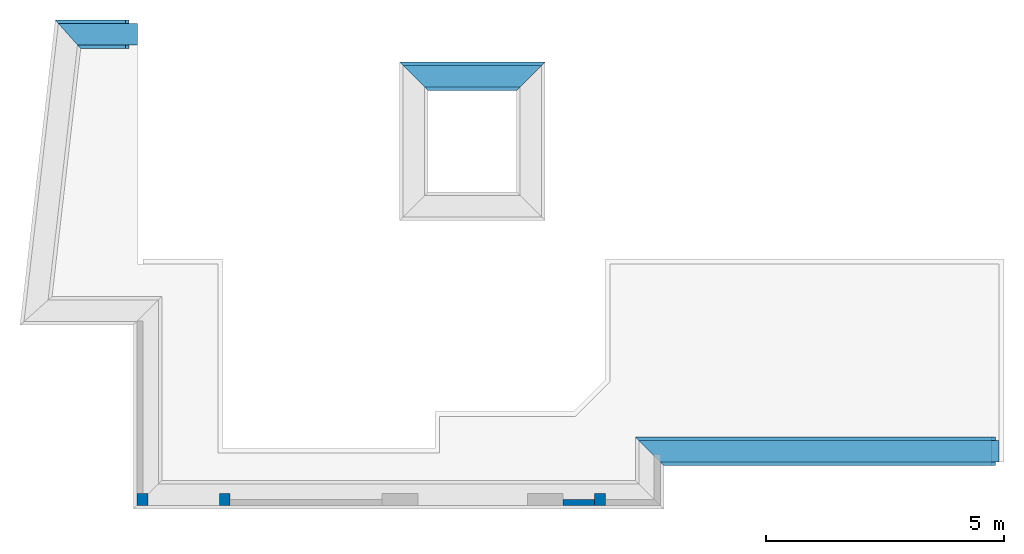
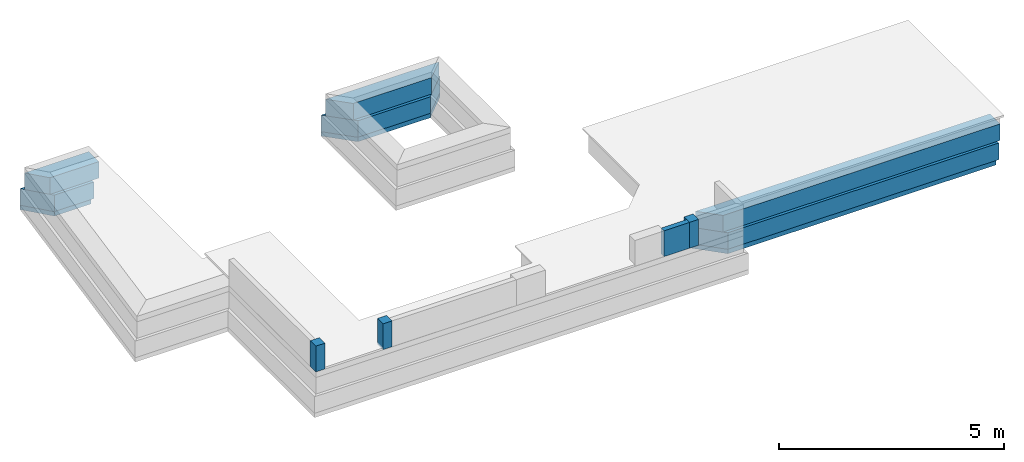
# One storey, part 2 of 4: 13 walls.
"""IFC4X3_ADD2 building model written with IfcOpenShell, lengths in metres."""

from ifc_helpers import new_model, entity, si_unit, converted_unit, frame, origin_with_axes, origin_2d_with_axis, place, context, subcontext, project, spatial, line, indexed_curve, outline, extrude, material, layer, layer_set, layer_usage, type_object, element, save


model = new_model("IFC4X3_ADD2")

# Units and contexts
model_context = context("Model", 3, precision=1e-05, world=origin_with_axes())
plan_context = context("Plan", 2, precision=1e-05, world=origin_2d_with_axis())
body_context = subcontext(model_context, "Body", "Model", "MODEL_VIEW")
ifc_project = project(units=[si_unit("VOLUMEUNIT", "CUBIC_METRE"), si_unit("LENGTHUNIT", "METRE"), converted_unit("PLANEANGLEUNIT", "degree", entity("IfcReal", 0.0174532925199433), si_unit("PLANEANGLEUNIT", "RADIAN"), dimensions=[0, 0, 0, 0, 0, 0, 0]), si_unit("AREAUNIT", "SQUARE_METRE")], contexts=[model_context, plan_context])

# Site, building, storey
site_placement = place(None, origin_with_axes())
site = spatial("IfcSite", under=ifc_project, at=site_placement)
building_placement = place(site_placement, origin_with_axes())
building = spatial("IfcBuilding", under=site, at=building_placement, Name="Building")
storey_placement = place(building_placement, origin_with_axes())
storey = spatial("IfcBuildingStorey", under=building, at=storey_placement, Name="Verandah")

# Walls
ifc_material_1 = material(Name="Stone", Category="Structure")
ifc_layer_1 = layer(ifc_material_1, 0.449999988079071)
ifc_layer_set_1 = layer_set([ifc_layer_1])
ifc_layer_usage_1 = layer_usage(ifc_layer_set_1, "AXIS2", "POSITIVE", 0.0)
wall_type_1 = type_object("IfcWallType", Name="RRB_0.45W", PredefinedType="SHEAR", material=ifc_layer_set_1)
wall_1_placement = place(storey_placement, frame((16.2040448841746, 11.6493488347191, -0.150000005960464), z_axis=(0.0, 0.0, 1.0), x_axis=(0.999999999999822, -5.960464477538e-07, 0.0)))
element("IfcWall", 1, at=wall_1_placement, inside=storey, type_object=wall_type_1, material=ifc_layer_usage_1, Name="Wall", context=body_context, shape_type="SweptSolid", body=[
    extrude(outline(indexed_curve([(0.0, 0.0), (-0.449999989155844, 0.449999988079071), (7.12097009124434, 0.449999988079071), (7.12097018937736, 0.0)], segments=[line(1, 2, 3, 4, 1)])), origin_with_axes(), (0.0, 0.0, 1.0), 0.449999988079071),
])
ifc_layer_usage_2 = layer_usage(ifc_layer_set_1, "AXIS2", "POSITIVE", 0.0)
wall_2_placement = place(storey_placement, frame((5.6390405123403, 20.8634834375414, -0.150000005960464), z_axis=(0.0, 0.0, 1.0), x_axis=(-0.999999999999803, 6.27832946520233e-07, 0.0)))
element("IfcWall", 2, at=wall_2_placement, inside=storey, type_object=wall_type_1, material=ifc_layer_usage_2, Name="Wall", context=body_context, shape_type="SweptSolid", body=[
    extrude(outline(indexed_curve([(0.425000000745078, 0.0), (0.424999862371063, 0.449999988079071), (1.68367306365502, 0.449999988079071), (2.08469309225921, 0.0)], segments=[line(1, 2, 3, 4, 1)])), origin_with_axes(), (0.0, 0.0, 1.0), 0.449999988079071),
])
ifc_layer_usage_3 = layer_usage(ifc_layer_set_1, "AXIS2", "POSITIVE", 0.0)
wall_3_placement = place(storey_placement, frame((13.7089599315482, 19.9843861870825, -0.150000020861626), z_axis=(0.0, 0.0, 1.0), x_axis=(-0.999999999999803, 6.27832946520233e-07, 0.0)))
element("IfcWall", 3, at=wall_3_placement, inside=storey, type_object=wall_type_1, material=ifc_layer_usage_3, Name="Wall", context=body_context, shape_type="SweptSolid", body=[
    extrude(outline(indexed_curve([(0.0, 0.0), (0.450000016741684, 0.449999988079071), (2.46327593529409, 0.449999988079071), (2.91327589750235, 0.0)], segments=[line(1, 2, 3, 4, 1)])), origin_with_axes(), (0.0, 0.0, 1.0), 0.449999988079071),
])
ifc_material_2 = material(Name="Wall")
ifc_layer_2 = layer(ifc_material_2, 0.600000023841858, Name="concrete")
ifc_layer_set_2 = layer_set([ifc_layer_2], Name="concrete")
ifc_layer_usage_4 = layer_usage(ifc_layer_set_2, "AXIS2", "POSITIVE", 0.0)
wall_type_2 = type_object("IfcWallType", Name="RRB_0.6W", PredefinedType="SHEAR", material=ifc_layer_set_2)
wall_4_placement = place(storey_placement, frame((23.8500140713483, 12.1743445783882, -0.600000023841858), z_axis=(0.0, 0.0, 1.0), x_axis=(-0.999999999999924, 3.89414367418765e-07, 0.0)))
element("IfcWall", 4, at=wall_4_placement, inside=storey, type_object=wall_type_2, material=ifc_layer_usage_4, Name="Wall", context=body_context, shape_type="SweptSolid", body=[
    extrude(outline(indexed_curve([(0.600000023841859, 0.0), (0.599999982986343, 0.600000023841858), (7.57096725031161, 0.600000023841858), (8.17096530502794, 0.0)], segments=[line(1, 2, 3, 4, 1)])), origin_with_axes(), (0.0, 0.0, 1.0), 0.449999988079071),
])
ifc_layer_usage_5 = layer_usage(ifc_layer_set_2, "AXIS2", "POSITIVE", 0.0)
wall_5_placement = place(storey_placement, frame((5.63904048850912, 20.9384838708685, -0.600000023841858), z_axis=(0.0, 0.0, 1.0), x_axis=(-0.999999999999803, 6.27832946520233e-07, 0.0)))
element("IfcWall", 5, at=wall_5_placement, inside=storey, type_object=wall_type_2, material=ifc_layer_usage_5, Name="Wall", context=body_context, shape_type="SweptSolid", body=[
    extrude(outline(indexed_curve([(0.600000023841886, 0.0), (0.599999839305639, 0.600000023841858), (1.61683742049565, 0.600000023841858), (2.15153083745776, 0.0)], segments=[line(1, 2, 3, 4, 1)])), origin_with_axes(), (0.0, 0.0, 1.0), 0.449999988079071),
])
ifc_layer_usage_6 = layer_usage(ifc_layer_set_2, "AXIS2", "POSITIVE", 0.0)
wall_6_placement = place(storey_placement, frame((10.7206868734936, 19.4593892768367, -0.600000023841858), z_axis=(0.0, 0.0, 1.0), x_axis=(0.999999999999886, -4.76837158203071e-07, 0.0)))
element("IfcWall", 6, at=wall_6_placement, inside=storey, type_object=wall_type_2, material=ifc_layer_usage_6, Name="Wall", context=body_context, shape_type="SweptSolid", body=[
    extrude(outline(indexed_curve([(0.600000023841886, 0.0), (6.56667492426315e-07, 0.600000023841858), (3.06327801910507, 0.600000023841858), (2.46327590943912, 0.0)], segments=[line(1, 2, 3, 4, 1)])), origin_with_axes(), (0.0, 0.0, 1.0), 0.449999988079071),
])
ifc_layer_3 = layer(ifc_material_2, 0.600000023841858, Name="concrete")
ifc_layer_set_3 = layer_set([ifc_layer_3])
ifc_layer_usage_7 = layer_usage(ifc_layer_set_3, "AXIS2", "POSITIVE", 0.0)
wall_type_3 = type_object("IfcWallType", PredefinedType="SHEAR", material=ifc_layer_set_3)
wall_7_placement = place(storey_placement, frame((23.9250147963809, 12.1743444907698, -0.720000028610229), z_axis=(0.0, 0.0, 1.0), x_axis=(-0.999999999999924, 3.89414367418765e-07, 0.0)))
element("IfcWall", 7, at=wall_7_placement, inside=storey, type_object=wall_type_3, material=ifc_layer_usage_7, Name="Wall", context=body_context, shape_type="SweptSolid", body=[
    extrude(outline(indexed_curve([(0.750000000000002, 0.0), (0.749999959106952, 0.600000023841858), (7.64596970538998, 0.600000023841858), (8.24596967911119, 0.0)], segments=[line(1, 2, 3, 4, 1)])), origin_with_axes(), (0.0, 0.0, 1.0), 0.119999997317791),
])
ifc_layer_usage_8 = layer_usage(ifc_layer_set_3, "AXIS2", "POSITIVE", 0.0)
wall_8_placement = place(storey_placement, frame((5.71404023001452, 20.9384838237812, -0.720000028610229), z_axis=(0.0, 0.0, 1.0), x_axis=(-0.999999999999803, 6.27832946520233e-07, 0.0)))
element("IfcWall", 8, at=wall_8_placement, inside=storey, type_object=wall_type_3, material=ifc_layer_usage_8, Name="Wall", context=body_context, shape_type="SweptSolid", body=[
    extrude(outline(indexed_curve([(0.750000000000036, 0.0), (0.749999815463788, 0.600000023841858), (1.69183711281799, 0.600000023841858), (2.22653052981391, 0.0)], segments=[line(1, 2, 3, 4, 1)])), origin_with_axes(), (0.0, 0.0, 1.0), 0.119999997317791),
])
ifc_layer_usage_9 = layer_usage(ifc_layer_set_3, "AXIS2", "POSITIVE", 0.0)
wall_9_placement = place(storey_placement, frame((10.7206830498575, 19.4593855981233, -0.720000028610229), z_axis=(0.0, 0.0, 1.0), x_axis=(0.999999999999822, -5.960464477538e-07, 0.0)))
element("IfcWall", 9, at=wall_9_placement, inside=storey, type_object=wall_type_3, material=ifc_layer_usage_9, Name="Wall", context=body_context, shape_type="SweptSolid", body=[
    extrude(outline(indexed_curve([(0.600000023841857, 0.0), (-7.15048348612532e-09, 0.600000023841858), (3.06327585045119, 0.600000023841858), (2.46327590942337, 0.0)], segments=[line(1, 2, 3, 4, 1)])), origin_with_axes(), (0.0, 0.0, 1.0), 0.119999997317791),
])
ifc_material_3 = material(Name="Plaster", Category="Finishes")
ifc_layer_4 = layer(ifc_material_3, 0.0149999996647239, Name="plaster")
ifc_material_4 = material(Name="Brick")
ifc_layer_5 = layer(ifc_material_4, 0.100000001490116, Name="brick")
ifc_layer_6 = layer(ifc_material_3, 0.0149999996647239, Name="plaster")
ifc_layer_set_4 = layer_set([ifc_layer_4, ifc_layer_5, ifc_layer_6], Name="brick2")
ifc_layer_usage_10 = layer_usage(ifc_layer_set_4, "AXIS2", "POSITIVE", 0.0)
wall_type_4 = type_object("IfcWallType", Name="Wall 130mm", PredefinedType="SOLIDWALL", material=ifc_layer_set_4)
wall_10_placement = place(storey_placement, frame((14.1583385467529, 10.7361326217651, 0.453000009059906), z_axis=(0.0, 0.0, 1.0), x_axis=(1.0, 0.0, 0.0)))
element("IfcWall", 10, at=wall_10_placement, inside=storey, type_object=wall_type_4, material=ifc_layer_usage_10, Name="Wall", context=body_context, shape_type="SweptSolid", body=[
    extrude(outline(indexed_curve([(0.0, 0.0), (0.0, 0.130000000819564), (0.65833568572998, 0.130000000819564), (0.65833568572998, 0.0)], segments=[line(1, 2, 3, 4, 1)])), origin_with_axes(), (0.0, 0.0, 1.0), 0.699999988079071),
])
ifc_layer_7 = layer(ifc_material_3, 0.00999999977648258, Name="plaster")
ifc_material_5 = material(Name="Brick")
ifc_layer_8 = layer(ifc_material_5, 0.230000004172325, Name="brick")
ifc_layer_9 = layer(ifc_material_3, 0.00999999977648258, Name="plaster")
ifc_layer_set_5 = layer_set([ifc_layer_7, ifc_layer_8, ifc_layer_9], Name="brick")
ifc_layer_usage_11 = layer_usage(ifc_layer_set_5, "AXIS2", "POSITIVE", 0.0)
wall_type_5 = type_object("IfcWallType", Name="Wall 250mm export", PredefinedType="SOLIDWALL", material=ifc_layer_set_5)
wall_11_placement = place(storey_placement, frame((5.20404190816946, 10.7361325292886, 0.453000009059906), z_axis=(0.0, 0.0, 1.0), x_axis=(0.999999999999744, -7.15255737304505e-07, 0.0)))
element("IfcWall", 11, at=wall_11_placement, inside=storey, type_object=wall_type_5, material=ifc_layer_usage_11, Name="Wall", context=body_context, shape_type="SweptSolid", body=[
    extrude(outline(indexed_curve([(0.0, 0.0), (0.0, 0.25000000372529), (0.230000024055699, 0.25000000372529), (0.230000024055699, 0.0)], segments=[line(1, 2, 3, 4, 1)])), origin_with_axes(), (0.0, 0.0, 1.0), 0.699999988079071),
])
ifc_layer_usage_12 = layer_usage(ifc_layer_set_5, "AXIS2", "POSITIVE", 0.0)
wall_12_placement = place(storey_placement, frame((6.93404145040579, 10.7361325292886, 0.453000009059906), z_axis=(0.0, 0.0, 1.0), x_axis=(0.999999999999744, -7.15255737304505e-07, 0.0)))
element("IfcWall", 12, at=wall_12_placement, inside=storey, type_object=wall_type_5, material=ifc_layer_usage_12, Name="Wall", context=body_context, shape_type="SweptSolid", body=[
    extrude(outline(indexed_curve([(0.0, 0.0), (0.0, 0.25000000372529), (0.230000024055699, 0.25000000372529), (0.230000024055699, 0.0)], segments=[line(1, 2, 3, 4, 1)])), origin_with_axes(), (0.0, 0.0, 1.0), 0.699999988079071),
])
ifc_layer_usage_13 = layer_usage(ifc_layer_set_5, "AXIS2", "POSITIVE", 0.0)
wall_13_placement = place(storey_placement, frame((14.8166741827971, 10.7361325292886, 0.453000009059906), z_axis=(0.0, 0.0, 1.0), x_axis=(0.999999999999744, -7.15255737304505e-07, 0.0)))
element("IfcWall", 13, at=wall_13_placement, inside=storey, type_object=wall_type_5, material=ifc_layer_usage_13, Name="Wall", context=body_context, shape_type="SweptSolid", body=[
    extrude(outline(indexed_curve([(0.0, 0.0), (0.0, 0.25000000372529), (0.230000024055699, 0.25000000372529), (0.230000024055699, 0.0)], segments=[line(1, 2, 3, 4, 1)])), origin_with_axes(), (0.0, 0.0, 1.0), 0.699999988079071),
])

save(model, "model.ifc")
